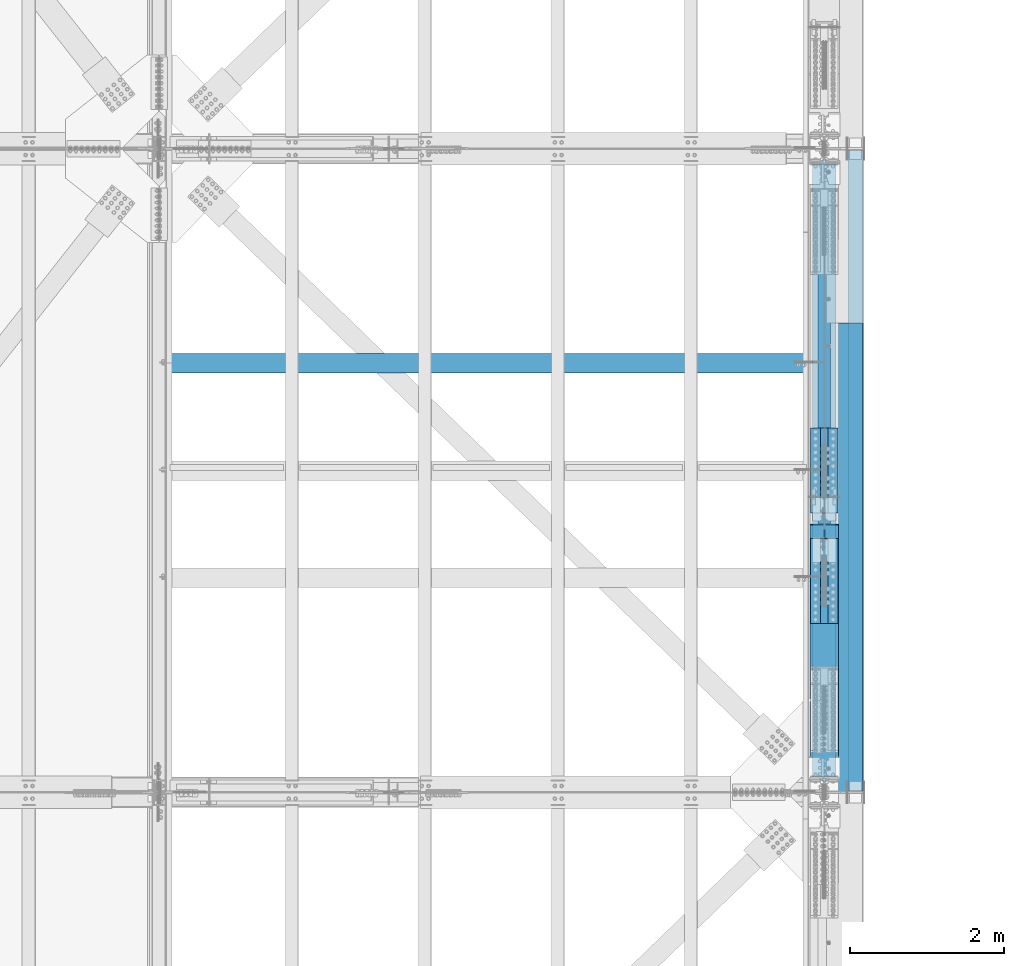
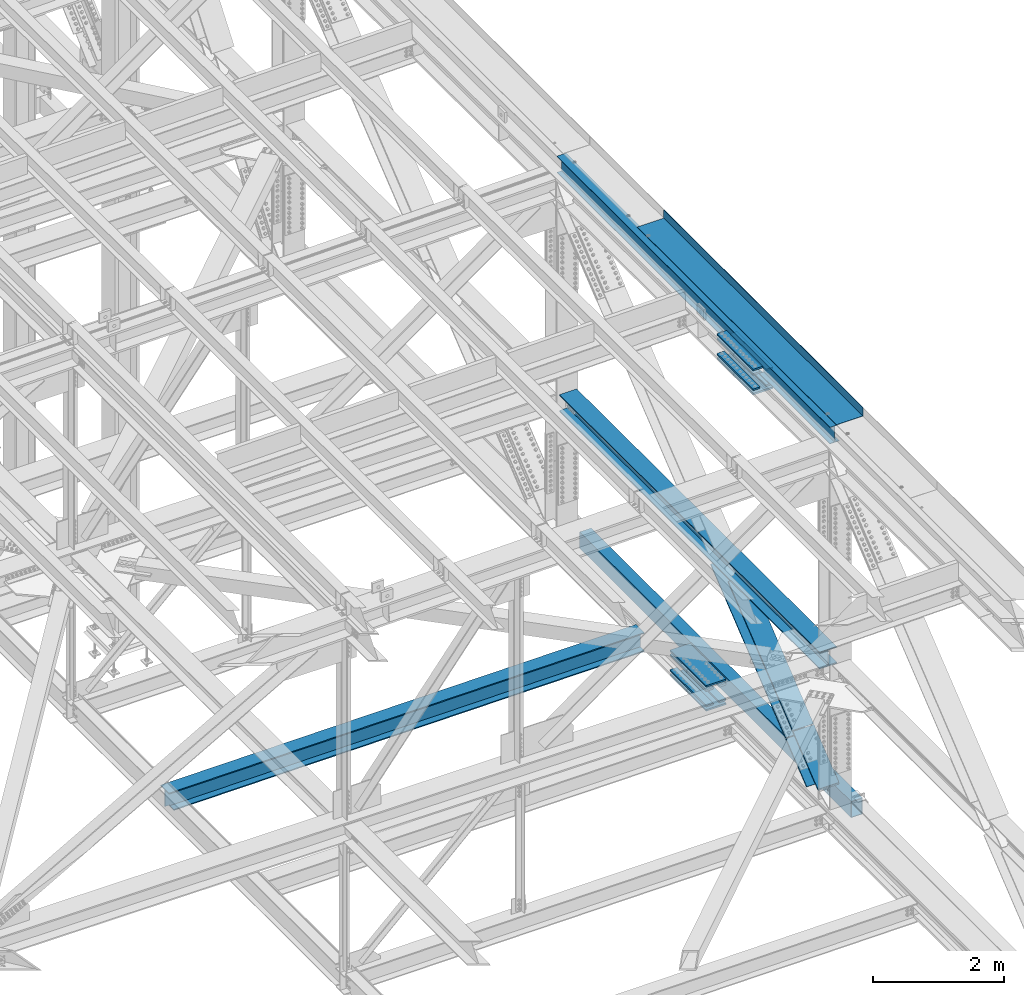
# One storey, part 1979 of 3843: 17 beams, 2 members, 7 elements without a shape of their own.
"""IFC2X3 building model written with IfcOpenShell, lengths in millimetres."""

from ifc_helpers import new_model, si_unit, frame, origin_with_axes, place, context, subcontext, project, spatial, faceted_brep, material, type_object, element, aggregate, save


model = new_model("IFC2X3")

# Units and contexts
model_context = context("Model", 3, precision=1e-05, world=origin_with_axes())
body_context = subcontext(model_context, "Body", "Model", "MODEL_VIEW")
ifc_project = project(units=[si_unit("LENGTHUNIT", "METRE", prefix="MILLI"), si_unit("AREAUNIT", "SQUARE_METRE"), si_unit("VOLUMEUNIT", "CUBIC_METRE"), si_unit("MASSUNIT", "GRAM", prefix="KILO"), si_unit("TIMEUNIT", "SECOND"), si_unit("PLANEANGLEUNIT", "RADIAN"), si_unit("SOLIDANGLEUNIT", "STERADIAN"), si_unit("THERMODYNAMICTEMPERATUREUNIT", "DEGREE_CELSIUS"), si_unit("LUMINOUSINTENSITYUNIT", "LUMEN")], contexts=[model_context])

# Site, building, storey
site_placement = place(None, origin_with_axes())
site = spatial("IfcSite", under=ifc_project, at=site_placement, CompositionType="ELEMENT")
building_placement = place(site_placement, origin_with_axes())
building = spatial("IfcBuilding", under=site, at=building_placement, Name="Undefined", CompositionType="ELEMENT")
storey_placement = place(building_placement, origin_with_axes())
storey = spatial("IfcBuildingStorey", under=building, at=storey_placement, Name="Undefined", CompositionType="ELEMENT", Elevation=0.0)

# Assembly, beam
assembly_1_placement = place(storey_placement, origin_with_axes())
assembly_1 = element("IfcElementAssembly", 1, at=assembly_1_placement, inside=storey, Name="BEAM", AssemblyPlace="NOTDEFINED", PredefinedType="RIGID_FRAME")
ifc_material_1 = material(Name="STEEL/A992")
beam_type_1 = type_object("IfcBeamType", Name="W12X26", PredefinedType="NOTDEFINED")
beam_1_placement = place(assembly_1_placement, frame((85648.8000000022, 67271.9, 46612.175), z_axis=(0.0, 0.0, 1.0), x_axis=(0.0, 1.0, 0.0)))
beam_1 = element("IfcBeam", 2, at=beam_1_placement, type_object=beam_type_1, material=ifc_material_1, Name="BEAM", ObjectType="W12X26", context=body_context, shape_type="Brep", body=[
    faceted_brep([(2165.34999999998, -3.17500000000291, -146.050000000003), (2165.34999999998, -82.5500000000029, -146.050000000003), (2165.34999999998, -82.5500000000029, -155.574999999997), (2165.34999999998, 82.5500000000029, -155.574999999997), (2165.34999999998, 82.5500000000029, -146.050000000003), (2165.34999999998, 3.17500000000291, -146.050000000003), (2165.34999999998, 3.17500000000291, -92.0750000000262), (2165.34999999998, -3.17500000000291, -92.0750000000262), (3321.04999999999, -3.17500000000291, -92.0750000000262), (3321.04999999999, 3.17500000000291, -92.0750000000262), (3321.04999999999, 3.17500000000291, -146.050000000003), (3321.04999999999, 82.5500000000029, -146.050000000003), (3321.04999999997, 82.5500000000029, -155.574999999997), (3321.04999999997, -82.5500000000029, -155.574999999997), (3321.04999999999, -82.5500000000029, -146.050000000003), (3321.04999999999, -3.17500000000291, -146.050000000003), (0.0, -82.5500000000029, 155.574999999997), (0.0, -82.5500000000029, 146.050000000003), (8356.60000000001, -82.5500000000029, 146.050000000003), (8356.60000000001, -82.5500000000029, 155.574999999997), (0.0, 82.5500000000029, 155.574999999997), (8356.60000000001, 82.5500000000029, 155.574999999997), (0.0, 82.5500000000029, 146.050000000003), (8356.60000000001, 82.5500000000029, 146.050000000003), (0.0, 3.17500000000291, 146.050000000003), (8356.60000000001, 3.17500000000291, 146.050000000003), (0.0, -82.5500000000029, -155.574999999997), (0.0, -82.5500000000029, -146.050000000003), (0.0, -3.17500000000291, -146.050000000003), (0.0, -3.17500000000291, 146.050000000003), (0.0, 3.17500000000291, -146.050000000003), (0.0, 82.5500000000029, -146.050000000003), (0.0, 82.5500000000029, -155.574999999997), (8356.60000000001, -3.17500000000291, 146.050000000003), (8356.60000000001, 3.17500000000291, -146.050000000003), (8356.60000000001, -3.17500000000291, -146.050000000003), (8356.60000000001, -82.5500000000029, -146.050000000003), (8356.60000000001, -82.5500000000029, -155.574999999997), (8356.60000000001, 82.5500000000029, -155.574999999997), (8356.60000000001, 82.5500000000029, -146.050000000003)], [[[0, 1, 2, 3, 4, 5, 6, 7]], [[8, 9, 10, 11, 12, 13, 14, 15]], [[7, 6, 9, 8]], [[16, 17, 18, 19]], [[20, 16, 19, 21]], [[22, 20, 21, 23]], [[24, 22, 23, 25]], [[26, 27, 28, 29, 17, 16, 20, 22, 24, 30, 31, 32]], [[17, 29, 33, 18]], [[34, 25, 23, 21, 19, 18, 33, 35, 36, 37, 38, 39]], [[36, 35, 15, 14]], [[37, 36, 14, 13]], [[38, 37, 13, 12]], [[39, 38, 12, 11]], [[34, 39, 11, 10]], [[5, 30, 24, 25, 34, 10, 9, 6]], [[31, 30, 5, 4]], [[32, 31, 4, 3]], [[26, 32, 3, 2]], [[27, 26, 2, 1]], [[28, 27, 1, 0]], [[35, 33, 29, 28, 0, 7, 8, 15]]]),
])

assembly_2_placement = place(storey_placement, origin_with_axes())
assembly_2 = element("IfcElementAssembly", 3, at=assembly_2_placement, inside=storey, Name="BEAM", AssemblyPlace="NOTDEFINED", PredefinedType="RIGID_FRAME")
ifc_material_2 = material()
beam_type_2 = type_object("IfcBeamType", Name="HSS12X8X3/8", PredefinedType="NOTDEFINED")
beam_2_placement = place(assembly_2_placement, frame((86055.2000000001, 75603.1, 39477.9499997994), z_axis=(0.0, 0.0, 1.0), x_axis=(0.0, -1.0, 0.0)))
beam_2 = element("IfcBeam", 4, at=beam_2_placement, type_object=beam_type_2, material=ifc_material_2, Name="BEAM", ObjectType="HSS12X8X3/8", context=body_context, shape_type="Brep", body=[
    faceted_brep([(0.0, 92.0749999999971, -142.875), (0.0, -92.0749999999971, -142.875), (8305.80000000002, -92.0749999999971, -142.875), (8305.80000000002, 92.0749999999971, -142.875), (0.0, -92.0749999999971, 142.875), (8305.80000000002, -92.0749999999971, 142.875), (0.0, 92.0749999999971, 142.875), (8305.80000000002, 92.0749999999971, 142.875), (0.0, 101.600000000006, -152.400000000001), (0.0, 101.600000000006, 152.400000000001), (8305.80000000002, 101.600000000006, 152.400000000001), (8305.80000000002, 101.600000000006, -152.400000000001), (0.0, -101.600000000006, 152.400000000001), (8305.80000000002, -101.600000000006, 152.400000000001), (0.0, -101.600000000006, -152.400000000001), (8305.80000000002, -101.600000000006, -152.400000000001)], [[[0, 1, 2, 3]], [[1, 4, 5, 2]], [[4, 6, 7, 5]], [[6, 0, 3, 7]], [[8, 9, 10, 11]], [[9, 12, 13, 10]], [[12, 14, 15, 13]], [[14, 8, 11, 15]], [[13, 15, 11, 10], [5, 7, 3, 2]], [[14, 12, 9, 8], [6, 4, 1, 0]]]),
])
aggregate(assembly_2, [beam_2])

# Assembly, beams
assembly_3_placement = place(storey_placement, origin_with_axes())
assembly_3 = element("IfcElementAssembly", 5, at=assembly_3_placement, inside=storey, Name="BEAM", AssemblyPlace="NOTDEFINED", PredefinedType="RIGID_FRAME")
ifc_material_3 = material(Name="STEEL/A572-50")
beam_type_3 = type_object("IfcBeamType", PredefinedType="NOTDEFINED")
beam_3_placement = place(assembly_3_placement, frame((85763.1, 70897.0129116201, 39396.0580627343), z_axis=(-1.0, 0.0, 0.0), x_axis=(0.0, 0.999997806647667, -0.00209444499925612)))
beam_3 = element("IfcBeam", 6, at=beam_3_placement, type_object=beam_type_3, material=ifc_material_3, Name="PLATE", context=body_context, shape_type="Brep", body=[
    faceted_brep([(8.73114913702011e-11, 15.8750000000073, -63.5), (8.73114913702011e-11, 15.8750000000073, 63.5), (1104.89999997285, 15.8750000015862, 63.5), (1104.89999997285, 15.8750000015862, -63.5), (-1.01863406598568e-10, -15.8750000000146, 63.5), (1104.89999997268, -15.8749999984284, 63.5), (-1.01863406598568e-10, -15.8750000000146, -63.5), (1104.89999997268, -15.8749999984284, -63.5)], [[[0, 1, 2, 3]], [[1, 4, 5, 2]], [[4, 6, 7, 5]], [[6, 0, 3, 7]], [[5, 7, 3, 2]], [[6, 4, 1, 0]]]),
])
beam_4_placement = place(assembly_3_placement, frame((85763.1, 70897.6179696293, 39684.9444885784), z_axis=(-1.0, 0.0, 0.0), x_axis=(0.0, 0.999997806647667, -0.00209444499925612)))
beam_4 = element("IfcBeam", 7, at=beam_4_placement, type_object=beam_type_3, material=ifc_material_3, Name="PLATE", context=body_context, shape_type="Brep", body=[
    faceted_brep([(8.73114913702011e-11, 15.8750000000073, -63.5), (8.73114913702011e-11, 15.8750000000073, 63.5), (1104.89999997285, 15.8750000015862, 63.5), (1104.89999997285, 15.8750000015862, -63.5), (-1.01863406598568e-10, -15.8750000000146, 63.5), (1104.89999997268, -15.8749999984284, 63.5), (-1.01863406598568e-10, -15.8750000000146, -63.5), (1104.89999997268, -15.8749999984284, -63.5)], [[[0, 1, 2, 3]], [[1, 4, 5, 2]], [[4, 6, 7, 5]], [[6, 0, 3, 7]], [[5, 7, 3, 2]], [[6, 4, 1, 0]]]),
])
beam_5_placement = place(assembly_3_placement, frame((85534.5, 70897.0129116201, 39396.0580627343), z_axis=(-1.0, 0.0, 0.0), x_axis=(0.0, 0.999997806647667, -0.00209444499925612)))
beam_5 = element("IfcBeam", 8, at=beam_5_placement, type_object=beam_type_3, material=ifc_material_3, Name="PLATE", context=body_context, shape_type="Brep", body=[
    faceted_brep([(8.73114913702011e-11, 15.8750000000073, -63.5), (8.73114913702011e-11, 15.8750000000073, 63.5), (1104.89999997285, 15.8750000015862, 63.5), (1104.89999997285, 15.8750000015862, -63.5), (-1.01863406598568e-10, -15.8750000000146, 63.5), (1104.89999997268, -15.8749999984284, 63.5), (-1.01863406598568e-10, -15.8750000000146, -63.5), (1104.89999997268, -15.8749999984284, -63.5)], [[[0, 1, 2, 3]], [[1, 4, 5, 2]], [[4, 6, 7, 5]], [[6, 0, 3, 7]], [[5, 7, 3, 2]], [[6, 4, 1, 0]]]),
])
beam_6_placement = place(assembly_3_placement, frame((85534.5, 70897.6179696293, 39684.9444885784), z_axis=(-1.0, 0.0, 0.0), x_axis=(0.0, 0.999997806647667, -0.00209444499925612)))
beam_6 = element("IfcBeam", 9, at=beam_6_placement, type_object=beam_type_3, material=ifc_material_3, Name="PLATE", context=body_context, shape_type="Brep", body=[
    faceted_brep([(8.73114913702011e-11, 15.8750000000073, -63.5), (8.73114913702011e-11, 15.8750000000073, 63.5), (1104.89999997285, 15.8750000015862, 63.5), (1104.89999997285, 15.8750000015862, -63.5), (-1.01863406598568e-10, -15.8750000000146, 63.5), (1104.89999997268, -15.8749999984284, 63.5), (-1.01863406598568e-10, -15.8750000000146, -63.5), (1104.89999997268, -15.8749999984284, -63.5)], [[[0, 1, 2, 3]], [[1, 4, 5, 2]], [[4, 6, 7, 5]], [[6, 0, 3, 7]], [[5, 7, 3, 2]], [[6, 4, 1, 0]]]),
])

assembly_4_placement = place(storey_placement, origin_with_axes())
assembly_4 = element("IfcElementAssembly", 10, at=assembly_4_placement, inside=storey, Name="BEAM", AssemblyPlace="NOTDEFINED", PredefinedType="RIGID_FRAME")
beam_7_placement = place(assembly_4_placement, frame((85763.1, 69461.9971708685, 46171.0318318112), z_axis=(-1.0, 0.0, 0.0), x_axis=(0.0, 0.999998280124082, -0.0018546560002281)))
beam_7 = element("IfcBeam", 11, at=beam_7_placement, type_object=beam_type_3, material=ifc_material_3, Name="PLATE", context=body_context, shape_type="Brep", body=[
    faceted_brep([(8.73114913702011e-11, 15.8750000000073, -63.5), (8.73114913702011e-11, 15.8750000000073, 63.5), (1104.89999997285, 15.8750000015862, 63.5), (1104.89999997285, 15.8750000015862, -63.5), (-1.01863406598568e-10, -15.8750000000146, 63.5), (1104.89999997268, -15.8749999984284, 63.5), (-1.01863406598568e-10, -15.8750000000146, -63.5), (1104.89999997268, -15.8749999984284, -63.5)], [[[0, 1, 2, 3]], [[1, 4, 5, 2]], [[4, 6, 7, 5]], [[6, 0, 3, 7]], [[5, 7, 3, 2]], [[6, 4, 1, 0]]]),
])
beam_8_placement = place(assembly_4_placement, frame((85763.1, 69462.5329858233, 46459.9339468382), z_axis=(-1.0, 0.0, 0.0), x_axis=(0.0, 0.999998280124082, -0.0018546560002281)))
beam_8 = element("IfcBeam", 12, at=beam_8_placement, type_object=beam_type_3, material=ifc_material_3, Name="PLATE", context=body_context, shape_type="Brep", body=[
    faceted_brep([(8.73114913702011e-11, 15.8750000000073, -63.5), (8.73114913702011e-11, 15.8750000000073, 63.5), (1104.89999997285, 15.8750000015862, 63.5), (1104.89999997285, 15.8750000015862, -63.5), (-1.01863406598568e-10, -15.8750000000146, 63.5), (1104.89999997268, -15.8749999984284, 63.5), (-1.01863406598568e-10, -15.8750000000146, -63.5), (1104.89999997268, -15.8749999984284, -63.5)], [[[0, 1, 2, 3]], [[1, 4, 5, 2]], [[4, 6, 7, 5]], [[6, 0, 3, 7]], [[5, 7, 3, 2]], [[6, 4, 1, 0]]]),
])
beam_9_placement = place(assembly_4_placement, frame((85534.5, 69461.9971708685, 46171.0318318112), z_axis=(-1.0, 0.0, 0.0), x_axis=(0.0, 0.999998280124082, -0.0018546560002281)))
beam_9 = element("IfcBeam", 13, at=beam_9_placement, type_object=beam_type_3, material=ifc_material_3, Name="PLATE", context=body_context, shape_type="Brep", body=[
    faceted_brep([(8.73114913702011e-11, 15.8750000000073, -63.5), (8.73114913702011e-11, 15.8750000000073, 63.5), (1104.89999997285, 15.8750000015862, 63.5), (1104.89999997285, 15.8750000015862, -63.5), (-1.01863406598568e-10, -15.8750000000146, 63.5), (1104.89999997268, -15.8749999984284, 63.5), (-1.01863406598568e-10, -15.8750000000146, -63.5), (1104.89999997268, -15.8749999984284, -63.5)], [[[0, 1, 2, 3]], [[1, 4, 5, 2]], [[4, 6, 7, 5]], [[6, 0, 3, 7]], [[5, 7, 3, 2]], [[6, 4, 1, 0]]]),
])
beam_10_placement = place(assembly_4_placement, frame((85534.5, 69462.5329858233, 46459.9339468382), z_axis=(-1.0, 0.0, 0.0), x_axis=(0.0, 0.999998280124082, -0.0018546560002281)))
beam_10 = element("IfcBeam", 14, at=beam_10_placement, type_object=beam_type_3, material=ifc_material_3, Name="PLATE", context=body_context, shape_type="Brep", body=[
    faceted_brep([(8.73114913702011e-11, 15.8750000000073, -63.5), (8.73114913702011e-11, 15.8750000000073, 63.5), (1104.89999997285, 15.8750000015862, 63.5), (1104.89999997285, 15.8750000015862, -63.5), (-1.01863406598568e-10, -15.8750000000146, 63.5), (1104.89999997268, -15.8749999984284, 63.5), (-1.01863406598568e-10, -15.8750000000146, -63.5), (1104.89999997268, -15.8749999984284, -63.5)], [[[0, 1, 2, 3]], [[1, 4, 5, 2]], [[4, 6, 7, 5]], [[6, 0, 3, 7]], [[5, 7, 3, 2]], [[6, 4, 1, 0]]]),
])

# Beam
beam_type_4 = type_object("IfcBeamType", PredefinedType="NOTDEFINED")
beam_11_placement = place(assembly_3_placement, frame((85648.8, 72001.7444334059, 39314.4448681872), z_axis=(-1.0, 0.0, 0.0), x_axis=(0.0, -0.999997806825691, 0.00209435999962985)))
beam_11 = element("IfcBeam", 15, at=beam_11_placement, type_object=beam_type_4, material=ifc_material_3, Name="PLATE", context=body_context, shape_type="Brep", body=[
    faceted_brep([(1.45519152283669e-11, 15.8750000000218, -177.800000000003), (1.45519152283669e-11, 15.8750000000218, 177.800000000003), (1104.89999996551, 15.8749999977663, 177.800000000003), (1104.89999996551, 15.8749999977663, -177.800000000003), (-4.36557456851006e-11, -15.8750000000146, 177.800000000003), (1104.89999996545, -15.8750000022774, 177.800000000003), (-4.36557456851006e-11, -15.8750000000146, -177.800000000003), (1104.89999996545, -15.8750000022774, -177.800000000003)], [[[0, 1, 2, 3]], [[1, 4, 5, 2]], [[4, 6, 7, 5]], [[6, 0, 3, 7]], [[5, 7, 3, 2]], [[6, 4, 1, 0]]]),
])

beam_12_placement = place(assembly_3_placement, frame((85648.8, 72002.6820323062, 39762.1195374423), z_axis=(-1.0, 0.0, 0.0), x_axis=(0.0, -0.999997806825691, 0.00209435999962985)))
beam_12 = element("IfcBeam", 16, at=beam_12_placement, type_object=beam_type_4, material=ifc_material_3, Name="PLATE", context=body_context, shape_type="Brep", body=[
    faceted_brep([(1.45519152283669e-11, 15.8750000000218, -177.800000000003), (1.45519152283669e-11, 15.8750000000218, 177.800000000003), (1104.89999996551, 15.8749999977663, 177.800000000003), (1104.89999996551, 15.8749999977663, -177.800000000003), (-4.36557456851006e-11, -15.8750000000146, 177.800000000003), (1104.89999996545, -15.8750000022774, 177.800000000003), (-4.36557456851006e-11, -15.8750000000146, -177.800000000003), (1104.89999996545, -15.8750000022774, -177.800000000003)], [[[0, 1, 2, 3]], [[1, 4, 5, 2]], [[4, 6, 7, 5]], [[6, 0, 3, 7]], [[5, 7, 3, 2]], [[6, 4, 1, 0]]]),
])

beam_13_placement = place(assembly_4_placement, frame((85648.8, 70566.7483896834, 46089.6824189132), z_axis=(-1.0, 0.0, 0.0), x_axis=(0.0, -0.999998280124082, 0.0018546560002281)))
beam_13 = element("IfcBeam", 17, at=beam_13_placement, type_object=beam_type_4, material=ifc_material_3, Name="PLATE", context=body_context, shape_type="Brep", body=[
    faceted_brep([(1.45519152283669e-11, 15.8750000000218, -177.800000000003), (1.45519152283669e-11, 15.8750000000218, 177.800000000003), (1104.89999996551, 15.8749999977663, 177.800000000003), (1104.89999996551, 15.8749999977663, -177.800000000003), (-4.36557456851006e-11, -15.8750000000146, 177.800000000003), (1104.89999996545, -15.8750000022774, 177.800000000003), (-4.36557456851006e-11, -15.8750000000146, -177.800000000003), (1104.89999996545, -15.8750000022774, -177.800000000003)], [[[0, 1, 2, 3]], [[1, 4, 5, 2]], [[4, 6, 7, 5]], [[6, 0, 3, 7]], [[5, 7, 3, 2]], [[6, 4, 1, 0]]]),
])

beam_14_placement = place(assembly_4_placement, frame((85648.8, 70567.5784866923, 46537.3608833708), z_axis=(-1.0, 0.0, 0.0), x_axis=(0.0, -0.999998280124082, 0.0018546560002281)))
beam_14 = element("IfcBeam", 18, at=beam_14_placement, type_object=beam_type_4, material=ifc_material_3, Name="PLATE", context=body_context, shape_type="Brep", body=[
    faceted_brep([(1.45519152283669e-11, 15.8750000000218, -177.800000000003), (1.45519152283669e-11, 15.8750000000218, 177.800000000003), (1104.89999996551, 15.8749999977663, 177.800000000003), (1104.89999996551, 15.8749999977663, -177.800000000003), (-4.36557456851006e-11, -15.8750000000146, 177.800000000003), (1104.89999996545, -15.8750000022774, 177.800000000003), (-4.36557456851006e-11, -15.8750000000146, -177.800000000003), (1104.89999996545, -15.8750000022774, -177.800000000003)], [[[0, 1, 2, 3]], [[1, 4, 5, 2]], [[4, 6, 7, 5]], [[6, 0, 3, 7]], [[5, 7, 3, 2]], [[6, 4, 1, 0]]]),
])

aggregate(assembly_4, [beam_7, beam_8, beam_9, beam_10, beam_13, beam_14])

# Assembly, member
assembly_5_placement = place(storey_placement, origin_with_axes())
assembly_5 = element("IfcElementAssembly", 19, at=assembly_5_placement, inside=storey, Name="V. BRACE", AssemblyPlace="NOTDEFINED", PredefinedType="RIGID_FRAME")
member_type = type_object("IfcMemberType", Name="W14X99", PredefinedType="NOTDEFINED")
member_1_placement = place(assembly_5_placement, frame((85648.8, 68344.5097444995, 40413.6328956517), z_axis=(0.0, -0.628617932148933, 0.777714276184255), x_axis=(0.0, 0.777714276184257, 0.628617932148931)))
member_1 = element("IfcMember", 20, at=member_1_placement, type_object=member_type, material=ifc_material_1, Name="V. BRACE", ObjectType="W14X99", context=body_context, shape_type="Brep", body=[
    faceted_brep([(2538.40676533413, -185.737500000003, 160.337500007345), (2538.40676533413, -6.35000000000582, 160.337500007345), (2538.40678365252, -6.35000000000582, 160.243934305132), (2538.40678365252, 6.35000000000582, 160.243934305132), (2538.40676533413, 6.35000000000582, 160.337500007345), (2538.40676533413, 185.737500000003, 160.337500007345), (2538.40305402549, 185.737500000003, 179.293934022864), (2538.40305402549, -185.737500000003, 179.293934022864), (6.42539160144224, 185.737500000003, 179.387499999799), (6.42539160144224, -185.737500000003, 179.387499999799), (2538.28774945826, -185.737500000003, 179.387500007311), (2538.28774945826, 185.737500000003, 179.387500007311), (6.43260191388254, 185.737500000003, -160.337499999774), (6.43260191388254, 6.35000000000582, -160.337499999774), (2884.35343699699, 6.35000000000582, -160.337499991218), (2884.35343699699, 185.737500000003, -160.337499991218), (2470.11252593005, -6.35000000000582, 137.459396987446), (2470.11252593005, 6.35000000000582, 137.459396987446), (2487.60678467534, 6.35000000000582, 160.23398873623), (2487.60678467534, -6.35000000000582, 160.23398873623), (2468.18740217322, -6.35000000000582, 132.593863504908), (2468.18740217322, 6.35000000000582, 132.593863504908), (2469.12283157113, -6.35000000000582, 127.445612404774), (2469.12283157113, 6.35000000000582, 127.445612404774), (2472.63651672797, -6.35000000000582, 123.56830223317), (2472.63651672797, 6.35000000000582, 123.56830223317), (2477.66808454497, -6.35000000000582, 122.132042211049), (2477.66808454497, 6.35000000000582, 122.132042211049), (2608.81397002525, 6.35000000000582, 122.157717908072), (2588.66361844048, -6.35000000000582, 122.153772879066), (2889.86586894853, -6.35000000000582, -122.262262092996), (2910.01622097682, 6.35000000000582, -122.258317024467), (2864.17892468568, -6.35000000000582, -122.267291124759), (2864.17892468568, 6.35000000000582, -122.267291124759), (2858.68024355263, -6.35000000000582, -124.016069630727), (2858.68024355263, 6.35000000000582, -124.016069630727), (2855.20010628784, -6.35000000000582, -128.618499976144), (2855.20010628784, 6.35000000000582, -128.618499976144), (2855.01562425381, -6.35000000000582, -134.385621168325), (2855.01562425381, 6.35000000000582, -134.385621168325), (2858.19449710834, -6.35000000000582, -139.201063810548), (2858.19449710834, 6.35000000000582, -139.201063810548), (2884.38541176292, -185.737500000003, -160.363335617871), (2884.38541176292, 185.737500000003, -160.363335617871), (2884.35343699699, -6.35000000000582, -160.337499991218), (2884.35343699699, -185.737500000003, -160.337499991218), (6.43260191388254, -6.35000000000582, -160.337499999774), (6.43260191388254, -185.737500000003, -160.337499999774), (6.4330062304798, -185.737500000003, -179.387499999744), (2956.89168575485, -185.737500000003, -179.387499990977), (2956.88795614039, -185.737500000003, -160.337499990999), (2917.49739106746, -185.737500000003, -160.337499991119), (6.4330062304798, 185.737500000003, -179.387499999744), (2956.89168575485, 185.737500000003, -179.387499990977), (2956.88795614039, 6.35000000000582, -160.337499990999), (2956.88795614039, 185.737500000003, -160.337499990999), (2917.49739106746, 185.737500000003, -160.337499991119), (2917.49739106746, 6.35000000000582, -160.337499991119), (2956.88795012319, 6.35000000000582, -160.306765501589), (2956.88795614039, -6.35000000000582, -160.337499990999), (2956.88795012319, -6.35000000000582, -160.306765501589), (2917.49739106746, -6.35000000000582, -160.337499991119), (6.42579591803951, -6.35000000000582, 160.33749999981), (6.42579591803951, -185.737500000003, 160.33749999981), (6.42579591803951, 185.737500000003, 160.33749999981), (6.42579591803951, 6.35000000000582, 160.33749999981)], [[[0, 1, 2, 3, 4, 5, 6, 7]], [[8, 9, 10, 11]], [[12, 13, 14, 15]], [[16, 17, 18, 19]], [[20, 21, 17, 16]], [[22, 23, 21, 20]], [[24, 25, 23, 22]], [[26, 27, 25, 24]], [[28, 27, 26, 29]], [[30, 31, 28, 29]], [[31, 30, 32, 33]], [[34, 35, 33, 32]], [[36, 37, 35, 34]], [[38, 39, 37, 36]], [[40, 41, 39, 38]], [[42, 43, 15, 14, 41, 40, 44, 45]], [[46, 47, 45, 44]], [[45, 47, 48, 49, 50, 51, 42]], [[48, 52, 53, 49]], [[54, 55, 56, 57]], [[54, 57, 58]], [[59, 50, 49, 53, 55, 54, 58, 60]], [[59, 60, 61]], [[50, 59, 61, 51]], [[60, 58, 57, 56, 43, 42, 51, 61]], [[55, 53, 52, 12, 15, 43, 56]], [[48, 47, 46, 62, 63, 9, 8, 64, 65, 13, 12, 52]], [[10, 9, 63, 0, 7]], [[11, 10, 7, 6]], [[64, 8, 11, 6, 5]], [[65, 64, 5, 4]], [[18, 17, 21, 23, 25, 27, 28, 31, 33, 35, 37, 39, 41, 14, 13, 65, 4, 3]], [[19, 18, 3, 2]], [[62, 46, 44, 40, 38, 36, 34, 32, 30, 29, 26, 24, 22, 20, 16, 19, 2, 1]], [[63, 62, 1, 0]]]),
])
aggregate(assembly_5, [member_1])

# Member
member_2_placement = place(assembly_3_placement, frame((85648.8, 67272.0018372347, 39546.6165472708), z_axis=(0.0, -0.628634438193607, 0.777700934239511), x_axis=(0.0, 0.777700934239509, 0.628634438193609)))
member_2 = element("IfcMember", 21, at=member_2_placement, type_object=member_type, material=ifc_material_1, Name="BEAM", ObjectType="W14X99", context=body_context, shape_type="Brep", body=[
    faceted_brep([(1372.85593544738, 185.737500000003, -179.387499997971), (1372.85593544738, -185.737500000003, -179.387499997971), (554.857239716541, -185.737500000003, -179.387499999248), (554.857239716541, 185.737500000003, -179.387499999248), (1372.85593544738, -185.737500000003, -160.337499997961), (554.847684256179, -185.737500000003, -160.33749999923), (1372.85593544738, -6.35000000000582, -160.337499997961), (554.847684256179, -6.35000000000582, -160.33749999923), (1372.85593544738, -6.35000000000582, 160.33750000221), (1372.85593544738, -185.737500000003, 160.33750000221), (409.137541474018, -185.737500000003, 160.337500000714), (409.137541474018, -6.35000000000582, 160.337500000714), (516.770657453599, 6.35000000000582, -131.43619434649), (496.643334445951, -6.35000000000582, -131.442239296019), (279.310394957225, -6.35000000000582, 45.2139589365979), (297.135892608698, 6.35000000000582, 47.0910121068591), (579.925565469428, 6.35000000000582, -131.41722668591), (579.925565469428, -6.35000000000582, -131.41722668591), (584.965854890019, 6.35000000000582, -132.858295545422), (584.965854890019, -6.35000000000582, -132.858295545422), (588.480284535472, 6.35000000000582, -136.748023192489), (588.480284535472, -6.35000000000582, -136.748023192489), (589.404317889013, 6.35000000000582, -141.908193660856), (589.404317889013, -6.35000000000582, -141.908193660856), (587.458061099693, 6.35000000000582, -146.77576815039), (587.458061099693, -6.35000000000582, -146.77576815039), (577.079940692347, 6.35000000000582, -160.171309707635), (577.079940692347, -6.35000000000582, -160.171309707635), (554.84757871856, 6.35000000000582, -160.127097615212), (554.84757871856, -6.35000000000582, -160.127097615212), (419.221904747217, -6.35000000000582, 147.327821035971), (421.169012540689, -6.35000000000582, 142.464264017657), (420.249749681767, -6.35000000000582, 137.306709226315), (416.742202469235, -6.35000000000582, 133.415369073999), (411.707439358623, -6.35000000000582, 131.967413256592), (349.169428642679, -6.35000000000582, 131.877358836653), (365.500797980989, 6.35000000000582, 131.900875926112), (411.707439358623, 6.35000000000582, 131.967413256592), (416.742202469235, 6.35000000000582, 133.415369073999), (420.249749681767, 6.35000000000582, 137.306709226315), (421.169012540689, 6.35000000000582, 142.464264017657), (419.221904747217, 6.35000000000582, 147.327821035971), (409.023875280371, -185.737500000003, 160.484138975313), (409.023875280371, 185.737500000003, 160.484138975313), (409.137541474018, 185.737500000003, 160.337500000714), (409.137541474018, 6.35000000000582, 160.337500000714), (1372.85593544738, 185.737500000003, 160.33750000221), (1372.85593544738, 6.35000000000582, 160.33750000221), (1372.85593544738, 6.35000000000582, -160.337499997961), (554.847684256179, 6.35000000000582, -160.33749999923), (1372.85593544738, 185.737500000003, -160.337499997961), (554.847684256179, 185.737500000003, -160.33749999923), (1372.85593544738, 185.737500000003, 179.387500002224), (1372.85593544738, -185.737500000003, 179.387500002224), (387.855207687287, 185.737500000003, 179.387500000703), (387.855207687287, -185.737500000003, 179.387500000703), (387.905507531686, 185.737500000003, 160.476771811529), (387.905507531686, -185.737500000003, 160.476771811529), (368.339694261726, -185.737500000003, 160.424729532777), (368.30019199547, -185.737500000003, 160.375824316718), (368.30019199547, 185.737500000003, 160.375824316718), (368.339694261726, 185.737500000003, 160.424729532777)], [[[0, 1, 2, 3]], [[1, 4, 5, 2]], [[4, 6, 7, 5]], [[8, 9, 10, 11]], [[12, 13, 14, 15]], [[16, 17, 13, 12]], [[17, 16, 18, 19]], [[19, 18, 20, 21]], [[21, 20, 22, 23]], [[23, 22, 24, 25]], [[25, 24, 26, 27]], [[27, 26, 28, 29]], [[6, 8, 11, 30, 31, 32, 33, 34, 35, 14, 13, 17, 19, 21, 23, 25, 27, 29, 7]], [[36, 15, 14, 35]], [[34, 37, 36, 35]], [[33, 38, 37, 34]], [[32, 39, 38, 33]], [[31, 40, 39, 32]], [[30, 41, 40, 31]], [[11, 10, 42, 43, 44, 45, 41, 30]], [[46, 47, 45, 44]], [[26, 24, 22, 20, 18, 16, 12, 15, 36, 37, 38, 39, 40, 41, 45, 47, 48, 49, 28]], [[48, 50, 51, 49]], [[2, 5, 7, 29, 28, 49, 51, 3]], [[50, 0, 3, 51]], [[48, 47, 46, 52, 53, 9, 8, 6, 4, 1, 0, 50]], [[53, 52, 54, 55]], [[55, 54, 56, 57]], [[42, 10, 9, 53, 55, 57, 58, 59]], [[43, 42, 59, 60]], [[56, 54, 52, 46, 44, 43, 60, 61]], [[57, 56, 61, 58]], [[60, 59, 58, 61]]]),
])

aggregate(assembly_3, [beam_3, beam_4, beam_5, beam_6, beam_11, beam_12, member_2])

# Assembly, beam
assembly_6_placement = place(storey_placement, origin_with_axes())
assembly_6 = element("IfcElementAssembly", 22, at=assembly_6_placement, inside=storey, Name="BEAM", AssemblyPlace="NOTDEFINED", PredefinedType="RIGID_FRAME")
beam_type_5 = type_object("IfcBeamType", Name="W12X87", PredefinedType="NOTDEFINED")
beam_15_placement = place(assembly_6_placement, frame((85648.8, 67271.333527172, 42316.9140215046), z_axis=(0.0, 0.00209444499925302, 0.999997806647667), x_axis=(0.0, 0.999997806647667, -0.00209444499925612)))
beam_15 = element("IfcBeam", 23, at=beam_15_placement, type_object=beam_type_5, material=ifc_material_1, Name="BEAM", ObjectType="W12X87", context=body_context, shape_type="Brep", body=[
    faceted_brep([(199.336986540715, -153.987500000003, -158.750000000182), (199.336986540715, 153.987500000003, -158.750000000182), (8159.0793052573, 153.987500000003, -158.750000026666), (8159.0793052573, -153.987500000003, -158.750000026666), (199.293763368958, -153.987500000003, -138.112500000243), (199.293763368958, -6.35000000000582, -138.112500000243), (198.715237839337, -6.35000000000582, 138.112499998912), (198.715237839337, -153.987500000003, 138.112499998912), (198.672014667594, -153.987500000003, 158.74999999885), (198.672014667594, 153.987500000003, 158.74999999885), (198.715237839337, 153.987500000003, 138.112499998912), (198.715237839337, 6.35000000000582, 138.112499998912), (199.293763368958, 6.35000000000582, -138.112500000243), (199.293763368958, 153.987500000003, -138.112500000243), (8159.03608208557, -153.987500000003, -138.112500026735), (8159.03608208557, -6.35000000000582, -138.112500026735), (8158.45755655595, -6.35000000000582, 138.112499972427), (8158.45755655595, -153.987500000003, 138.112499972427), (8158.41433338421, -153.987500000003, 158.749999972359), (8158.41433338421, 153.987500000003, 158.749999972359), (8158.45755655595, 153.987500000003, 138.112499972427), (8158.45755655595, 6.35000000000582, 138.112499972427), (8159.03608208557, 6.35000000000582, -138.112500026735), (8159.03608208557, 153.987500000003, -138.112500026735)], [[[0, 1, 2, 3]], [[0, 4, 5, 6, 7, 8, 9, 10, 11, 12, 13, 1]], [[5, 4, 14, 15]], [[6, 5, 15, 16]], [[7, 6, 16, 17]], [[8, 7, 17, 18]], [[9, 8, 18, 19]], [[10, 9, 19, 20]], [[11, 10, 20, 21]], [[12, 11, 21, 22]], [[13, 12, 22, 23]], [[1, 13, 23, 2]], [[22, 21, 20, 19, 18, 17, 16, 15, 14, 3, 2, 23]], [[4, 0, 3, 14]]]),
])
aggregate(assembly_6, [beam_15])

# Beam
ifc_material_4 = material(Name="STEEL/A36")
beam_type_6 = type_object("IfcBeamType", PredefinedType="NOTDEFINED")
beam_16_placement = place(assembly_1_placement, frame((85680.5500000022, 70319.9, 46772.5125), z_axis=(0.0, -1.0, 0.0), x_axis=(1.0, 0.0, 0.0)))
beam_16 = element("IfcBeam", 24, at=beam_16_placement, type_object=beam_type_6, material=ifc_material_4, Name="BENT_PLATE", context=body_context, shape_type="Brep", body=[
    faceted_brep([(466.724998474107, 4.76249999999709, -3044.82500004767), (469.899999921181, 1.58750004768081, -3048.0), (0.0, 1.58750004768081, -3048.0), (0.0, 4.76249999999709, -3044.82500004768), (466.725000000006, 160.337499999994, -3044.82500004767), (469.900001478221, 160.337499968853, -3048.0), (0.0, 4.76249999999709, 3048.0), (466.724998474107, 4.76249999999709, 3048.0), (0.0, -4.76249999999709, -3048.0), (0.0, -4.76249999999709, 3048.0), (476.249998380677, -4.76249999999709, -3048.0), (476.249998380677, -4.76249999999709, 3048.0), (466.725000000006, 160.337499999994, 3048.0), (476.25, 160.337499906571, 3048.0), (476.25, 160.337499906571, -3048.0)], [[[0, 1, 2, 3]], [[4, 5, 1, 0]], [[6, 7, 0, 3]], [[8, 9, 6, 3, 2]], [[9, 8, 10, 11]], [[7, 12, 4, 0]], [[7, 6, 9, 11, 13, 12]], [[11, 10, 14, 13]], [[5, 14, 10, 8, 2, 1]], [[12, 13, 14, 5, 4]]]),
])

aggregate(assembly_1, [beam_16, beam_1])

# Assembly, beam
assembly_7_placement = place(storey_placement, origin_with_axes())
assembly_7 = element("IfcElementAssembly", 25, at=assembly_7_placement, inside=storey, Name="BEAM", AssemblyPlace="NOTDEFINED", PredefinedType="RIGID_FRAME")
beam_type_7 = type_object("IfcBeamType", Name="W14X68", PredefinedType="NOTDEFINED")
beam_17_placement = place(assembly_7_placement, frame((77011.5654237821, 72842.040632, 39446.1957137323), z_axis=(-0.00694362299832574, 0.0, 0.999975892759249), x_axis=(0.999975892759249, 0.0, 0.00694362299832789)))
beam_17 = element("IfcBeam", 26, at=beam_17_placement, type_object=beam_type_7, material=ifc_material_1, Name="BEAM", ObjectType="W14X68", context=body_context, shape_type="Brep", body=[
    faceted_brep([(18.477155512126, -5.55624999999418, -146.050000000141), (18.477155512126, 5.55624999999418, -146.050000000141), (94.4566903574596, 5.55624999999418, -146.050000000258), (94.4566903574596, -5.55624999999418, -146.050000000258), (99.3167698754987, 5.55624999999418, -147.016729922849), (99.3167698754987, -5.55624999999418, -147.016729922849), (103.436946343645, 5.55624999999418, -149.76974382333), (103.436946343645, -5.55624999999418, -149.76974382333), (106.189960244097, 5.55624999999418, -153.889920291484), (106.189960244097, -5.55624999999418, -153.889920291484), (107.156690166681, 5.55624999999418, -158.750000000073), (107.156690166681, -5.55624999999418, -158.750000000073), (107.156690166681, -127.0, -158.749999809523), (107.156690166681, 127.0, -158.750000000073), (107.156690166652, 127.0, -177.800000000068), (107.156690166652, -127.0, -177.800000000068), (20.5936228242208, 5.55624999999418, 158.749999999905), (20.5936228242208, 127.0, 158.749999999905), (8422.63992296961, 127.0, 158.749999988053), (8422.63992296961, 5.55624999999418, 158.749999988053), (20.725902031234, 127.0, 177.799999999894), (8422.77220217661, 127.0, 177.799999988041), (20.725902031234, -127.0, 177.799999999894), (8422.77220217661, -127.0, 177.799999988041), (20.5936228242208, -127.0, 158.749999999905), (8422.63992296961, -127.0, 158.749999988053), (20.5936228242208, -5.55624999999418, 158.749999999905), (8422.63992296961, -5.55624999999418, 158.749999988053), (8420.43526951953, 5.55624999999418, -158.750000011802), (8420.43526951953, -5.55624999999418, -158.750000011802), (8420.43526951953, -127.0, -158.750000011802), (8420.30299031253, -127.0, -177.80000001179), (8420.30299031253, 127.0, -177.80000001179), (8420.43526951953, 127.0, -158.750000011802), (18.7734824662621, 5.55624999999418, -103.374899325871), (20.3746819296794, 5.55624999999418, 127.219541544197)], [[[0, 1, 2, 3]], [[3, 2, 4, 5]], [[5, 4, 6, 7]], [[7, 6, 8, 9]], [[9, 8, 10, 11]], [[12, 11, 10, 13, 14, 15]], [[16, 17, 18, 19]], [[17, 20, 21, 18]], [[20, 22, 23, 21]], [[22, 24, 25, 23]], [[24, 26, 27, 25]], [[28, 19, 18, 21, 23, 25, 27, 29, 30, 31, 32, 33]], [[31, 30, 12, 15]], [[32, 31, 15, 14]], [[33, 32, 14, 13]], [[28, 33, 13, 10]], [[6, 4, 2, 1, 34, 35, 16, 19, 28, 10, 8]], [[26, 24, 22, 20, 17, 16, 35, 34, 1, 0]], [[29, 27, 26, 0, 3, 5, 7, 9, 11]], [[30, 29, 11, 12]]]),
])
aggregate(assembly_7, [beam_17])

save(model, "model.ifc")
